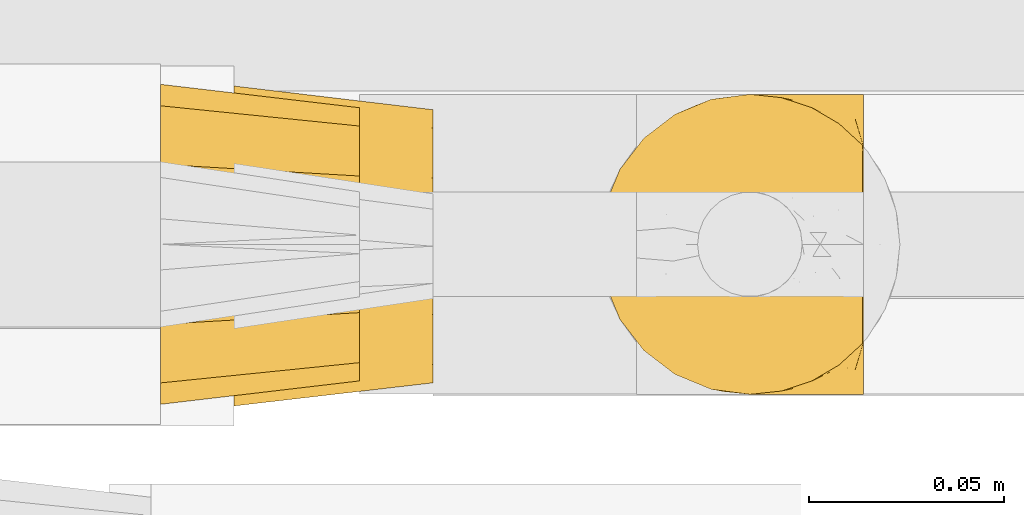
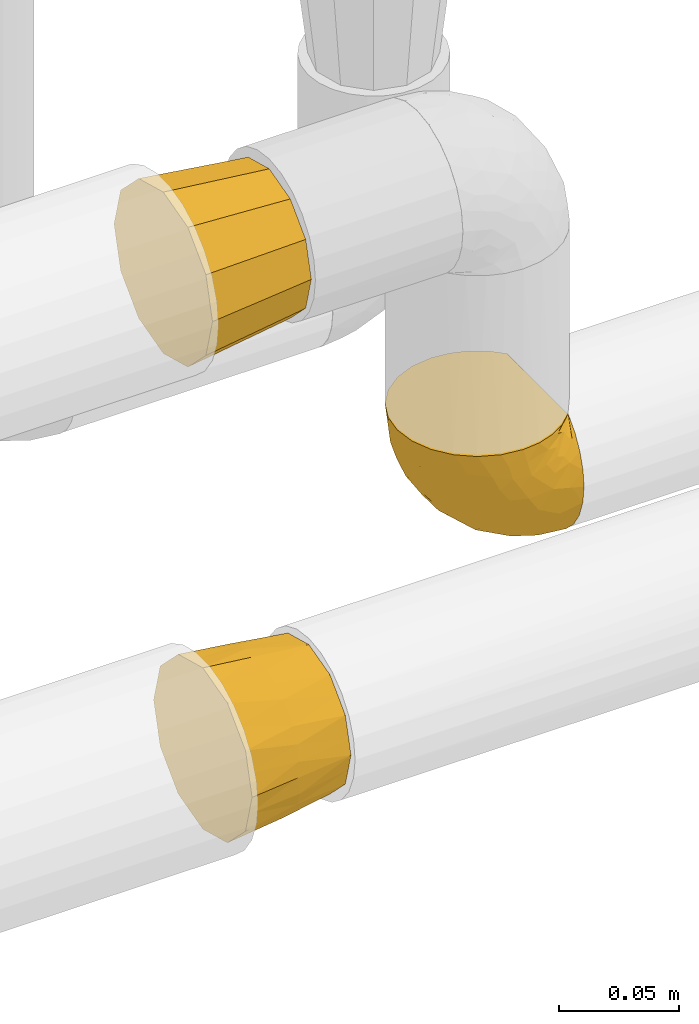
# One storey, part 472 of 827: 3 coverings.
"""IFC2X3 building model written with IfcOpenShell, lengths in millimetres."""

from ifc_helpers import new_model, entity, si_unit, converted_unit, derived_unit, direction, frame, origin, place, context, subcontext, project, spatial, faceted_brep, element, save


model = new_model("IFC2X3")

# Units and contexts
model_context = context("Model", 3, precision=0.01, world=origin(), true_north=direction((6.12303176911189e-17, 1.0)))
body_context = subcontext(model_context, "Body", "Model", "MODEL_VIEW")
ifc_project = project(units=[si_unit("LENGTHUNIT", "METRE", prefix="MILLI"), si_unit("AREAUNIT", "SQUARE_METRE"), si_unit("VOLUMEUNIT", "CUBIC_METRE"), converted_unit("PLANEANGLEUNIT", "DEGREE", entity("IfcRatioMeasure", 0.0174532925199433), si_unit("PLANEANGLEUNIT", "RADIAN"), dimensions=[0, 0, 0, 0, 0, 0, 0]), si_unit("MASSUNIT", "GRAM", prefix="KILO"), derived_unit("MASSDENSITYUNIT", [(si_unit("MASSUNIT", "GRAM", prefix="KILO"), 1), (si_unit("LENGTHUNIT", "METRE"), -3)]), derived_unit("MOMENTOFINERTIAUNIT", [(si_unit("LENGTHUNIT", "METRE"), 4)]), si_unit("TIMEUNIT", "SECOND"), si_unit("FREQUENCYUNIT", "HERTZ"), si_unit("THERMODYNAMICTEMPERATUREUNIT", "DEGREE_CELSIUS"), derived_unit("THERMALTRANSMITTANCEUNIT", [(si_unit("MASSUNIT", "GRAM", prefix="KILO"), 1), (si_unit("THERMODYNAMICTEMPERATUREUNIT", "KELVIN"), -1), (si_unit("TIMEUNIT", "SECOND"), -3)]), derived_unit("VOLUMETRICFLOWRATEUNIT", [(si_unit("LENGTHUNIT", "METRE"), 3), (si_unit("TIMEUNIT", "SECOND"), -1)]), derived_unit("MASSFLOWRATEUNIT", [(si_unit("MASSUNIT", "GRAM", prefix="KILO"), 1), (si_unit("TIMEUNIT", "SECOND"), -1)]), derived_unit("ROTATIONALFREQUENCYUNIT", [(si_unit("TIMEUNIT", "SECOND"), -1)]), si_unit("ELECTRICCURRENTUNIT", "AMPERE"), si_unit("ELECTRICVOLTAGEUNIT", "VOLT"), si_unit("POWERUNIT", "WATT"), si_unit("FORCEUNIT", "NEWTON", prefix="KILO"), si_unit("ILLUMINANCEUNIT", "LUX"), si_unit("LUMINOUSFLUXUNIT", "LUMEN"), si_unit("LUMINOUSINTENSITYUNIT", "CANDELA"), derived_unit("USERDEFINED", [(si_unit("MASSUNIT", "GRAM", prefix="KILO"), -1), (si_unit("LENGTHUNIT", "METRE"), -2), (si_unit("TIMEUNIT", "SECOND"), 3), (si_unit("LUMINOUSFLUXUNIT", "LUMEN"), 1)]), derived_unit("LINEARVELOCITYUNIT", [(si_unit("LENGTHUNIT", "METRE"), 1), (si_unit("TIMEUNIT", "SECOND"), -1)]), si_unit("PRESSUREUNIT", "PASCAL"), derived_unit("USERDEFINED", [(si_unit("LENGTHUNIT", "METRE"), -2), (si_unit("MASSUNIT", "GRAM", prefix="KILO"), 1), (si_unit("TIMEUNIT", "SECOND"), -2)]), derived_unit("LINEARFORCEUNIT", [(si_unit("MASSUNIT", "GRAM", prefix="KILO"), 1), (si_unit("LENGTHUNIT", "METRE"), 1), (si_unit("TIMEUNIT", "SECOND"), -2), (si_unit("LENGTHUNIT", "METRE"), -1)]), derived_unit("PLANARFORCEUNIT", [(si_unit("MASSUNIT", "GRAM", prefix="KILO"), 1), (si_unit("LENGTHUNIT", "METRE"), 1), (si_unit("TIMEUNIT", "SECOND"), -2), (si_unit("LENGTHUNIT", "METRE"), -2)])], contexts=[model_context])

# Site, building, storey
site_placement = place(None, origin())
site = spatial("IfcSite", under=ifc_project, at=site_placement, CompositionType="ELEMENT")
building_placement = place(site_placement, origin())
building = spatial("IfcBuilding", under=site, at=building_placement, CompositionType="ELEMENT")
storey_placement = place(building_placement, frame((0.0, 0.0, 28200.0)))
storey = spatial("IfcBuildingStorey", under=building, at=storey_placement, Name="08", CompositionType="ELEMENT", Elevation=28200.0)

# Coverings
covering_1_placement = place(storey_placement, frame((59573.82, 16439.61, 1059.95)))
element("IfcCovering", 1, at=covering_1_placement, inside=storey, Name=":ADSK_", ObjectType=":ADSK_", PredefinedType="INSULATION", context=body_context, shape_type="Brep", body=[
    faceted_brep([(69.15, 5.41, 23.36), (69.15, 9.99, 16.07), (69.15, 16.08, 9.98), (69.15, 23.37, 5.4), (69.15, 31.49, 2.56), (69.15, 40.05, 1.6), (69.15, 48.61, 2.56), (69.15, 56.73, 5.41), (69.15, 64.02, 9.99), (69.15, 70.11, 16.08), (69.15, 74.69, 23.37), (69.15, 77.53, 31.49), (69.15, 78.5, 40.05), (69.15, 77.63, 48.15), (69.15, 75.08, 55.88), (69.15, 70.97, 62.9), (69.15, 65.47, 68.89), (69.15, 63.27, 68.89), (69.15, 61.53, 68.89), (69.15, 59.57, 68.89), (69.15, 57.6, 68.89), (69.15, 55.63, 68.89), (69.15, 53.67, 68.89), (69.15, 51.7, 68.89), (69.15, 49.73, 68.89), (69.15, 47.54, 68.89), (69.15, 45.34, 68.89), (69.15, 43.15, 68.89), (69.15, 40.96, 68.89), (69.15, 38.76, 68.89), (69.15, 36.57, 68.89), (69.15, 34.37, 68.89), (69.15, 32.18, 68.89), (69.15, 29.98, 68.89), (69.15, 27.79, 68.89), (69.15, 25.6, 68.89), (69.15, 23.4, 68.89), (69.15, 21.21, 68.89), (69.15, 19.01, 68.89), (69.15, 16.82, 68.89), (69.15, 14.62, 68.89), (69.15, 9.12, 62.89), (69.15, 5.0, 55.86), (69.15, 2.46, 48.13), (69.15, 1.6, 40.05), (69.15, 2.56, 31.49), (68.89, 65.47, 69.15), (62.89, 70.97, 69.15), (55.87, 75.09, 69.15), (48.14, 77.63, 69.15), (40.05, 78.5, 69.15), (30.09, 77.19, 69.15), (20.82, 73.34, 69.15), (12.86, 67.23, 69.15), (6.75, 59.27, 69.15), (2.91, 50.0, 69.15), (1.6, 40.05, 69.15), (2.91, 30.09, 69.15), (6.75, 20.82, 69.15), (12.86, 12.86, 69.15), (20.82, 6.75, 69.15), (30.09, 2.91, 69.15), (40.05, 1.6, 69.15), (48.14, 2.46, 69.15), (55.87, 5.0, 69.15), (62.89, 9.12, 69.15), (68.89, 14.62, 69.15), (68.89, 16.82, 69.15), (68.89, 17.8, 69.15), (68.89, 19.39, 69.15), (68.89, 20.98, 69.15), (68.89, 22.57, 69.15), (68.89, 24.16, 69.15), (68.89, 25.75, 69.15), (68.89, 27.33, 69.15), (68.89, 28.92, 69.15), (68.89, 30.51, 69.15), (68.89, 32.1, 69.15), (68.89, 33.69, 69.15), (68.89, 35.28, 69.15), (68.89, 36.87, 69.15), (68.89, 38.46, 69.15), (68.89, 40.05, 69.15), (68.89, 41.63, 69.15), (68.89, 43.22, 69.15), (68.89, 44.81, 69.15), (68.89, 46.4, 69.15), (68.89, 47.99, 69.15), (68.89, 49.58, 69.15), (68.89, 51.17, 69.15), (68.89, 52.76, 69.15), (68.89, 54.72, 69.15), (68.89, 56.69, 69.15), (68.89, 58.88, 69.15), (68.89, 61.08, 69.15), (68.89, 63.27, 69.15), (68.97, 37.77, 68.96), (68.96, 36.07, 68.97), (68.97, 32.96, 68.97), (68.97, 31.36, 68.97), (68.98, 56.52, 68.95), (68.97, 54.96, 68.96), (68.96, 18.75, 68.98), (68.96, 58.07, 68.97), (68.96, 50.37, 68.97), (68.96, 23.36, 68.98), (68.96, 24.95, 68.97), (68.96, 42.43, 68.97), (69.0, 15.97, 68.94), (68.96, 51.96, 68.98), (68.96, 53.47, 68.98), (68.97, 48.63, 68.96), (68.96, 63.93, 68.97), (68.96, 40.93, 68.98), (68.96, 29.72, 68.98), (68.97, 62.4, 68.97), (68.97, 60.92, 68.96), (68.97, 17.31, 68.97), (68.96, 21.74, 68.97), (68.96, 34.56, 68.98), (68.97, 20.18, 68.96), (68.97, 14.62, 68.97), (69.02, 14.62, 68.94), (69.08, 14.62, 68.92), (68.97, 65.47, 68.97), (68.94, 65.47, 69.02), (68.92, 65.47, 69.08), (68.96, 59.5, 68.98), (68.96, 47.1, 68.97), (68.95, 45.61, 68.98), (68.96, 28.18, 68.97), (68.92, 14.62, 69.08), (68.94, 14.62, 69.02), (68.98, 26.61, 68.96), (69.08, 65.47, 68.92), (69.02, 65.47, 68.94), (68.96, 39.32, 68.97), (68.97, 44.12, 68.96), (61.33, 72.26, 67.02), (53.1, 76.57, 63.33), (63.33, 71.77, 64.61), (49.27, 78.5, 49.27), (55.53, 77.9, 51.4), (54.6, 78.5, 43.94), (41.99, 78.5, 61.87), (57.07, 75.52, 61.54), (57.95, 76.13, 57.95), (51.56, 77.81, 56.12), (41.58, 78.5, 63.4), (61.7, 72.4, 65.41), (63.33, 76.56, 53.1), (65.0, 71.77, 63.04), (67.02, 72.25, 61.33), (61.87, 78.5, 41.99), (43.94, 78.5, 54.6), (61.21, 75.75, 56.6), (63.4, 78.5, 41.58), (33.11, 50.46, 13.72), (52.82, 52.75, 5.82), (43.3, 40.05, 6.74), (33.73, 77.7, 58.82), (36.52, 77.66, 51.58), (24.87, 71.02, 42.09), (14.17, 63.45, 46.12), (18.43, 70.55, 55.56), (28.67, 75.57, 52.38), (26.0, 75.57, 61.54), (49.25, 72.61, 23.76), (59.72, 72.61, 20.5), (55.1, 67.24, 14.64), (44.72, 77.74, 41.77), (34.15, 57.43, 16.28), (5.25, 47.19, 49.4), (6.75, 54.76, 52.34), (55.54, 40.05, 4.3), (10.47, 63.45, 58.67), (25.49, 60.1, 25.26), (35.53, 63.72, 20.17), (48.22, 76.83, 34.7), (58.71, 76.34, 28.67), (57.42, 60.51, 8.62), (34.84, 72.59, 33.37), (36.87, 76.05, 41.35), (45.01, 66.15, 17.15), (44.4, 60.51, 12.68), (23.96, 51.88, 21.47), (11.2, 55.34, 41.11), (10.56, 48.67, 37.53), (16.81, 53.89, 30.64), (17.38, 46.73, 26.66), (21.38, 40.05, 21.38), (32.34, 40.05, 14.06), (4.3, 40.05, 55.54), (20.65, 63.95, 35.17), (29.66, 67.24, 29.04), (39.6, 69.62, 24.34), (42.55, 73.6, 29.33), (6.74, 40.05, 43.3), (14.06, 40.05, 32.34), (26.84, 4.52, 57.75), (5.28, 32.72, 49.41), (18.52, 27.18, 27.85), (33.13, 29.63, 13.7), (55.1, 12.86, 14.63), (57.43, 19.59, 8.61), (20.72, 9.54, 48.85), (11.46, 16.64, 54.13), (17.69, 17.48, 37.84), (49.26, 7.49, 23.75), (59.73, 7.49, 20.49), (58.71, 3.75, 28.66), (29.72, 20.75, 20.83), (35.35, 2.33, 55.15), (43.94, 1.6, 54.6), (41.99, 1.6, 61.87), (63.4, 1.6, 41.58), (4.93, 26.94, 57.58), (17.46, 9.54, 59.91), (10.94, 31.21, 36.94), (8.92, 25.33, 45.72), (52.83, 27.35, 5.82), (29.34, 8.17, 37.91), (30.26, 4.3, 50.18), (44.4, 19.59, 12.67), (39.06, 2.23, 49.29), (43.06, 2.45, 42.64), (54.6, 1.6, 43.94), (49.27, 1.6, 49.27), (42.69, 12.86, 19.45), (48.2, 3.27, 34.7), (61.87, 1.6, 41.99), (33.44, 2.29, 62.29), (29.67, 12.86, 29.01), (38.5, 6.89, 31.47), (23.35, 12.43, 37.18), (34.97, 4.1, 43.45), (53.1, 3.53, 63.33), (59.68, 6.88, 67.23), (62.19, 8.16, 66.07), (64.11, 9.02, 65.22), (57.97, 5.0, 61.99), (57.95, 3.96, 57.95), (63.33, 3.52, 53.09), (51.77, 2.4, 56.84), (67.02, 7.83, 61.33), (64.98, 8.32, 63.06), (55.53, 2.19, 51.41), (61.22, 4.34, 56.61)], [[[0, 1, 2, 3, 4, 5, 6, 7, 8, 9, 10, 11, 12, 13, 14, 15, 16, 17, 18, 19, 20, 21, 22, 23, 24, 25, 26, 27, 28, 29, 30, 31, 32, 33, 34, 35, 36, 37, 38, 39, 40, 41, 42, 43, 44, 45]], [[46, 47, 48, 49, 50, 51, 52, 53, 54, 55, 56, 57, 58, 59, 60, 61, 62, 63, 64, 65, 66, 67, 68, 69, 70, 71, 72, 73, 74, 75, 76, 77, 78, 79, 80, 81, 82, 83, 84, 85, 86, 87, 88, 89, 90, 91, 92, 93, 94, 95]], [[96, 97, 30]], [[98, 77, 99]], [[100, 101, 21]], [[69, 68, 102]], [[20, 19, 103]], [[24, 23, 104]], [[20, 103, 100]], [[72, 105, 106]], [[84, 83, 107]], [[89, 88, 104]], [[108, 67, 66]], [[109, 110, 90]], [[111, 25, 24]], [[112, 17, 16]], [[82, 113, 83]], [[109, 23, 22]], [[114, 76, 75]], [[105, 36, 106]], [[104, 111, 24]], [[18, 115, 116]], [[97, 96, 80]], [[67, 108, 117]], [[105, 71, 118]], [[31, 97, 119]], [[102, 120, 69]], [[108, 121, 122, 123, 40]], [[112, 95, 115]], [[17, 115, 18]], [[94, 116, 115]], [[117, 68, 67]], [[38, 117, 39]], [[112, 124, 125, 126, 46]], [[17, 112, 115]], [[70, 120, 118]], [[39, 117, 108]], [[120, 38, 37]], [[120, 37, 118]], [[120, 70, 69]], [[116, 94, 127]], [[128, 86, 129]], [[117, 38, 102]], [[74, 130, 75]], [[99, 33, 32]], [[115, 95, 94]], [[39, 108, 40]], [[108, 66, 131, 132, 121]], [[105, 72, 71]], [[118, 37, 36]], [[71, 70, 118]], [[35, 106, 36]], [[36, 105, 118]], [[35, 133, 106]], [[74, 73, 133]], [[106, 133, 73]], [[99, 114, 33]], [[133, 35, 34]], [[73, 72, 106]], [[95, 112, 46]], [[112, 16, 134, 135, 124]], [[130, 114, 75]], [[99, 76, 114]], [[114, 130, 33]], [[34, 33, 130]], [[78, 77, 98]], [[98, 119, 78]], [[130, 133, 34]], [[133, 130, 74]], [[79, 97, 80]], [[98, 99, 32]], [[98, 32, 31]], [[77, 76, 99]], [[97, 79, 119]], [[136, 96, 29]], [[30, 97, 31]], [[136, 29, 28]], [[81, 80, 96]], [[29, 96, 30]], [[31, 119, 98]], [[119, 79, 78]], [[96, 136, 81]], [[82, 81, 136]], [[113, 107, 83]], [[84, 107, 137]], [[107, 27, 137]], [[113, 28, 107]], [[27, 107, 28]], [[85, 84, 137]], [[137, 27, 26]], [[113, 136, 28]], [[136, 113, 82]], [[109, 89, 104]], [[86, 85, 129]], [[89, 109, 90]], [[111, 87, 128]], [[26, 129, 137]], [[88, 111, 104]], [[25, 111, 128]], [[22, 110, 109]], [[23, 109, 104]], [[110, 91, 90]], [[100, 92, 101]], [[110, 22, 101]], [[91, 110, 101]], [[116, 19, 18]], [[111, 88, 87]], [[127, 103, 19]], [[25, 128, 26]], [[86, 128, 87]], [[128, 129, 26]], [[137, 129, 85]], [[120, 102, 38]], [[117, 102, 68]], [[91, 101, 92]], [[21, 101, 22]], [[93, 92, 103]], [[100, 21, 20]], [[100, 103, 92]], [[127, 93, 103]], [[93, 127, 94]], [[116, 127, 19]], [[126, 138, 47]], [[48, 138, 139]], [[140, 125, 124]], [[141, 142, 143]], [[144, 49, 139]], [[145, 140, 146]], [[48, 139, 49]], [[139, 145, 147]], [[49, 144, 148, 50]], [[126, 125, 149]], [[14, 13, 150]], [[151, 146, 140]], [[149, 140, 145]], [[152, 151, 135]], [[152, 14, 150]], [[16, 15, 134]], [[13, 153, 150]], [[124, 151, 140]], [[141, 147, 142]], [[14, 152, 15]], [[15, 152, 134]], [[47, 46, 126]], [[139, 154, 144]], [[138, 48, 47]], [[125, 140, 149]], [[135, 134, 152]], [[146, 155, 142]], [[145, 146, 147]], [[149, 139, 138]], [[147, 141, 154]], [[147, 146, 142]], [[139, 147, 154]], [[139, 149, 145]], [[149, 138, 126]], [[155, 146, 151]], [[150, 143, 142]], [[152, 155, 151]], [[150, 142, 155]], [[13, 12, 156, 153]], [[153, 143, 150]], [[152, 150, 155]], [[151, 124, 135]], [[157, 158, 159]], [[160, 154, 161]], [[162, 163, 164]], [[165, 166, 160]], [[167, 168, 169]], [[141, 170, 161]], [[156, 12, 11]], [[158, 157, 171]], [[172, 55, 173]], [[158, 6, 174]], [[175, 54, 53]], [[52, 166, 164]], [[52, 164, 53]], [[54, 175, 173]], [[166, 52, 51]], [[176, 177, 171]], [[178, 143, 179]], [[156, 11, 179]], [[8, 7, 180]], [[169, 9, 8]], [[179, 143, 153, 156]], [[179, 11, 10]], [[168, 179, 10]], [[181, 162, 182]], [[179, 167, 178]], [[183, 184, 177]], [[183, 169, 184]], [[176, 171, 185]], [[172, 186, 187]], [[158, 7, 6]], [[159, 158, 174]], [[184, 180, 158]], [[54, 173, 55]], [[180, 169, 8]], [[188, 189, 187]], [[9, 168, 10]], [[186, 188, 187]], [[190, 157, 159, 191]], [[55, 172, 192]], [[176, 193, 194]], [[161, 170, 182]], [[162, 164, 165]], [[175, 164, 163]], [[51, 50, 148]], [[167, 195, 196]], [[178, 182, 170]], [[6, 5, 174]], [[158, 180, 7]], [[169, 180, 184]], [[169, 168, 9]], [[179, 168, 167]], [[182, 162, 165]], [[162, 194, 193]], [[161, 165, 160]], [[195, 181, 196]], [[192, 172, 197]], [[192, 56, 55]], [[189, 190, 198]], [[198, 197, 187]], [[172, 187, 197]], [[185, 189, 188]], [[198, 187, 189]], [[186, 172, 173]], [[173, 163, 186]], [[193, 186, 163]], [[176, 185, 188]], [[185, 157, 190]], [[188, 186, 193]], [[177, 176, 194]], [[188, 193, 176]], [[162, 193, 163]], [[195, 177, 194]], [[171, 177, 184]], [[181, 195, 194]], [[183, 167, 169]], [[162, 181, 194]], [[196, 182, 178]], [[158, 171, 184]], [[171, 157, 185]], [[177, 195, 183]], [[167, 183, 195]], [[182, 196, 181]], [[178, 170, 143]], [[178, 167, 196]], [[164, 175, 53]], [[173, 175, 163]], [[160, 51, 148]], [[164, 166, 165]], [[51, 160, 166]], [[160, 148, 144, 154]], [[141, 161, 154]], [[182, 165, 161]], [[190, 189, 185]], [[143, 170, 141]], [[60, 199, 61]], [[197, 200, 192]], [[201, 190, 202]], [[200, 57, 192]], [[203, 204, 2]], [[205, 206, 207]], [[208, 209, 210]], [[211, 207, 201]], [[212, 213, 214]], [[45, 215, 210]], [[216, 206, 58]], [[45, 44, 215]], [[59, 217, 60]], [[60, 217, 199]], [[0, 45, 210]], [[218, 201, 219]], [[202, 159, 220]], [[205, 221, 222]], [[223, 204, 203]], [[1, 203, 2]], [[57, 200, 216]], [[220, 3, 204]], [[220, 174, 4]], [[1, 0, 209]], [[212, 224, 213]], [[225, 226, 227]], [[228, 223, 203]], [[208, 210, 229]], [[210, 226, 229]], [[3, 220, 4]], [[58, 206, 59]], [[209, 203, 1]], [[202, 220, 223]], [[228, 203, 208]], [[202, 211, 201]], [[3, 2, 204]], [[202, 190, 191, 159]], [[210, 215, 230, 226]], [[199, 212, 231]], [[232, 233, 221]], [[233, 208, 229]], [[207, 206, 219]], [[217, 206, 205]], [[227, 224, 225]], [[233, 232, 228]], [[201, 207, 219]], [[234, 232, 221]], [[218, 219, 200]], [[202, 223, 211]], [[174, 220, 159]], [[174, 5, 4]], [[61, 231, 62]], [[220, 204, 223]], [[210, 209, 0]], [[203, 209, 208]], [[225, 233, 229]], [[224, 227, 213]], [[221, 233, 235]], [[57, 56, 192]], [[198, 218, 197]], [[200, 219, 216]], [[201, 198, 190]], [[197, 218, 200]], [[198, 201, 218]], [[206, 216, 219]], [[58, 57, 216]], [[231, 212, 214]], [[222, 212, 199]], [[228, 211, 223]], [[207, 211, 232]], [[62, 231, 214]], [[199, 231, 61]], [[233, 228, 208]], [[211, 228, 232]], [[222, 221, 235]], [[234, 205, 207]], [[206, 217, 59]], [[199, 217, 205]], [[205, 222, 199]], [[224, 222, 235]], [[222, 224, 212]], [[224, 235, 225]], [[233, 225, 235]], [[226, 225, 229]], [[205, 234, 221]], [[207, 232, 234]], [[63, 214, 236]], [[214, 213, 236]], [[214, 63, 62]], [[237, 236, 238]], [[238, 132, 131]], [[236, 237, 64]], [[239, 240, 241]], [[63, 236, 64]], [[131, 66, 65]], [[237, 131, 65]], [[242, 230, 43]], [[237, 65, 64]], [[239, 121, 132]], [[42, 242, 43]], [[241, 240, 243]], [[41, 123, 244]], [[43, 230, 215, 44]], [[244, 122, 245]], [[227, 246, 243]], [[241, 247, 245]], [[121, 239, 245]], [[41, 40, 123]], [[132, 238, 239]], [[244, 42, 41]], [[131, 237, 238]], [[240, 239, 238]], [[245, 239, 241]], [[247, 241, 246]], [[247, 244, 245]], [[238, 236, 240]], [[243, 236, 213]], [[236, 243, 240]], [[227, 226, 246]], [[243, 213, 227]], [[242, 246, 226]], [[243, 246, 241]], [[246, 242, 247]], [[244, 247, 242]], [[242, 226, 230]], [[42, 244, 242]], [[122, 244, 123]], [[122, 121, 245]]]),
])
covering_2_placement = place(storey_placement, frame((59462.86, 16437.06, 1205.86)))
element("IfcCovering", 2, at=covering_2_placement, inside=storey, Name=":ADSK_", ObjectType=":ADSK_", PredefinedType="INSULATION", context=body_context, shape_type="Brep", body=[
    faceted_brep([(51.0, 9.94, 51.35), (51.0, 7.6, 42.6), (51.0, 9.94, 33.85), (51.0, 12.28, 25.1), (51.0, 18.69, 18.69), (51.0, 25.1, 12.28), (51.0, 33.85, 9.94), (51.0, 42.6, 7.6), (51.0, 51.35, 9.94), (51.0, 60.1, 12.28), (51.0, 66.5, 18.69), (51.0, 72.91, 25.1), (51.0, 75.25, 33.85), (51.0, 77.6, 42.6), (51.0, 75.25, 51.35), (51.0, 72.91, 60.1), (51.0, 66.5, 66.5), (51.0, 60.1, 72.91), (51.0, 51.35, 75.25), (51.0, 42.6, 77.6), (51.0, 33.85, 75.25), (51.0, 25.1, 72.91), (51.0, 18.69, 66.5), (51.0, 12.28, 60.1), (0.0, 70.6, 70.6), (0.0, 78.1, 63.1), (0.0, 79.76, 56.92), (0.0, 81.68, 49.76), (0.0, 83.6, 42.6), (0.0, 81.68, 35.43), (0.0, 79.76, 28.27), (0.0, 78.1, 22.1), (0.0, 70.6, 14.59), (0.0, 63.1, 7.09), (0.0, 56.92, 5.43), (0.0, 49.76, 3.51), (0.0, 42.6, 1.6), (0.0, 35.43, 3.51), (0.0, 28.27, 5.43), (0.0, 22.1, 7.09), (0.0, 14.59, 14.59), (0.0, 7.09, 22.1), (0.0, 5.43, 28.27), (0.0, 3.51, 35.43), (0.0, 1.6, 42.6), (0.0, 3.51, 49.76), (0.0, 5.43, 56.92), (0.0, 7.09, 63.1), (0.0, 14.59, 70.6), (0.0, 22.1, 78.1), (0.0, 28.27, 79.76), (0.0, 35.43, 81.68), (0.0, 42.6, 83.6), (0.0, 49.76, 81.68), (0.0, 56.92, 79.76), (0.0, 63.1, 78.1)], [[[0, 1, 2, 3, 4, 5, 6, 7, 8, 9, 10, 11, 12, 13, 14, 15, 16, 17, 18, 19, 20, 21, 22, 23]], [[24, 25, 26, 27, 28, 29, 30, 31, 32, 33, 34, 35, 36, 37, 38, 39, 40, 41, 42, 43, 44, 45, 46, 47, 48, 49, 50, 51, 52, 53, 54, 55]], [[5, 39, 38, 37, 36, 7, 6]], [[41, 40, 39, 5, 4, 3]], [[43, 42, 41, 3, 2, 1, 44]], [[11, 31, 30, 29, 28, 13, 12]], [[33, 32, 31, 11, 10, 9]], [[35, 34, 33, 9, 8, 7, 36]], [[17, 55, 54, 53, 52, 19, 18]], [[25, 24, 55, 17, 16, 15]], [[27, 26, 25, 15, 14, 13, 28]], [[23, 47, 46, 45, 44, 1, 0]], [[49, 48, 47, 23, 22, 21]], [[51, 50, 49, 21, 20, 19, 52]]]),
])
covering_3_placement = place(storey_placement, frame((59481.64, 16436.63, 957.72)))
element("IfcCovering", 3, at=covering_3_placement, inside=storey, Name=":ADSK_", ObjectType=":ADSK_", PredefinedType="INSULATION", context=body_context, shape_type="Brep", body=[
    faceted_brep([(0.0, 70.6, 70.6), (0.0, 78.1, 63.1), (0.0, 80.85, 52.85), (0.0, 83.6, 42.6), (0.0, 80.85, 32.35), (0.0, 78.1, 22.1), (0.0, 70.6, 14.59), (0.0, 63.1, 7.09), (0.0, 52.85, 4.34), (0.0, 42.6, 1.6), (0.0, 32.35, 4.34), (0.0, 22.1, 7.09), (0.0, 14.59, 14.59), (0.0, 7.09, 22.1), (0.0, 4.34, 32.35), (0.0, 1.6, 42.6), (0.0, 4.34, 52.85), (0.0, 7.09, 63.1), (0.0, 14.59, 70.6), (0.0, 22.1, 78.1), (0.0, 32.35, 80.85), (0.0, 42.6, 83.6), (0.0, 52.85, 80.85), (0.0, 63.1, 78.1), (51.0, 77.53, 42.6), (51.0, 75.19, 51.35), (51.0, 72.84, 60.1), (51.0, 66.44, 66.5), (51.0, 60.03, 72.91), (51.0, 49.52, 75.72), (51.0, 42.53, 77.6), (51.0, 33.78, 75.25), (51.0, 25.03, 72.91), (51.0, 18.63, 66.5), (51.0, 12.22, 60.1), (51.0, 9.4, 49.58), (51.0, 7.53, 42.6), (51.0, 9.88, 33.85), (51.0, 12.22, 25.1), (51.0, 18.63, 18.69), (51.0, 25.03, 12.28), (51.0, 35.54, 9.47), (51.0, 42.53, 7.6), (51.0, 51.28, 9.94), (51.0, 60.03, 12.28), (51.0, 66.44, 18.69), (51.0, 72.84, 25.1), (51.0, 75.66, 35.61), (25.5, 77.67, 28.05), (24.37, 79.97, 35.15), (25.5, 73.89, 21.08), (23.51, 42.57, 4.36), (25.5, 65.7, 12.45), (25.5, 58.93, 8.3), (23.51, 80.8, 42.6), (25.5, 52.01, 5.79), (25.5, 28.02, 7.49), (24.37, 35.12, 5.19), (25.5, 21.05, 11.27), (23.51, 4.33, 42.6), (25.5, 12.42, 19.46), (25.5, 8.27, 26.22), (25.5, 5.76, 33.15), (25.5, 7.46, 57.14), (24.37, 5.16, 50.04), (25.5, 11.24, 64.11), (23.51, 42.57, 80.83), (25.5, 19.43, 72.74), (25.5, 26.19, 76.89), (25.5, 33.12, 79.4), (25.5, 57.11, 77.7), (24.36, 50.01, 80.0), (25.5, 64.08, 73.92), (25.5, 72.71, 65.73), (25.5, 76.86, 58.97), (25.5, 79.37, 52.04)], [[[0, 1, 2, 3, 4, 5, 6, 7, 8, 9, 10, 11, 12, 13, 14, 15, 16, 17, 18, 19, 20, 21, 22, 23]], [[24, 25, 26, 27, 28, 29, 30, 31, 32, 33, 34, 35, 36, 37, 38, 39, 40, 41, 42, 43, 44, 45, 46, 47]], [[47, 48, 49]], [[49, 24, 47]], [[48, 47, 46]], [[5, 4, 48]], [[50, 5, 48]], [[48, 4, 49]], [[51, 9, 8]], [[52, 50, 45]], [[50, 48, 46]], [[7, 52, 53]], [[53, 52, 44]], [[45, 44, 52]], [[50, 46, 45]], [[54, 24, 49, 3]], [[52, 6, 50]], [[6, 5, 50]], [[6, 52, 7]], [[55, 8, 53]], [[53, 43, 55]], [[53, 44, 43]], [[3, 49, 4]], [[8, 7, 53]], [[42, 51, 55]], [[42, 55, 43]], [[51, 8, 55]], [[41, 56, 57]], [[57, 42, 41]], [[56, 41, 40]], [[11, 10, 56]], [[58, 11, 56]], [[56, 10, 57]], [[59, 15, 14]], [[60, 58, 39]], [[58, 56, 40]], [[13, 60, 61]], [[61, 60, 38]], [[39, 38, 60]], [[58, 40, 39]], [[51, 42, 57, 9]], [[60, 12, 58]], [[12, 11, 58]], [[12, 60, 13]], [[62, 14, 61]], [[61, 37, 62]], [[61, 38, 37]], [[9, 57, 10]], [[14, 13, 61]], [[36, 59, 62]], [[36, 62, 37]], [[59, 14, 62]], [[35, 63, 64]], [[64, 36, 35]], [[63, 35, 34]], [[17, 16, 63]], [[65, 17, 63]], [[63, 16, 64]], [[66, 21, 20]], [[67, 65, 33]], [[65, 63, 34]], [[19, 67, 68]], [[68, 67, 32]], [[33, 32, 67]], [[65, 34, 33]], [[59, 36, 64, 15]], [[67, 18, 65]], [[18, 17, 65]], [[18, 67, 19]], [[69, 20, 68]], [[68, 31, 69]], [[68, 32, 31]], [[15, 64, 16]], [[20, 19, 68]], [[30, 66, 69]], [[30, 69, 31]], [[66, 20, 69]], [[29, 70, 71]], [[71, 30, 29]], [[70, 29, 28]], [[23, 22, 70]], [[72, 23, 70]], [[70, 22, 71]], [[54, 3, 2]], [[73, 72, 27]], [[72, 70, 28]], [[1, 73, 74]], [[74, 73, 26]], [[27, 26, 73]], [[72, 28, 27]], [[66, 30, 71, 21]], [[73, 0, 72]], [[0, 23, 72]], [[0, 73, 1]], [[75, 2, 74]], [[74, 25, 75]], [[74, 26, 25]], [[21, 71, 22]], [[2, 1, 74]], [[24, 54, 75]], [[24, 75, 25]], [[54, 2, 75]]]),
])

save(model, "model.ifc")
